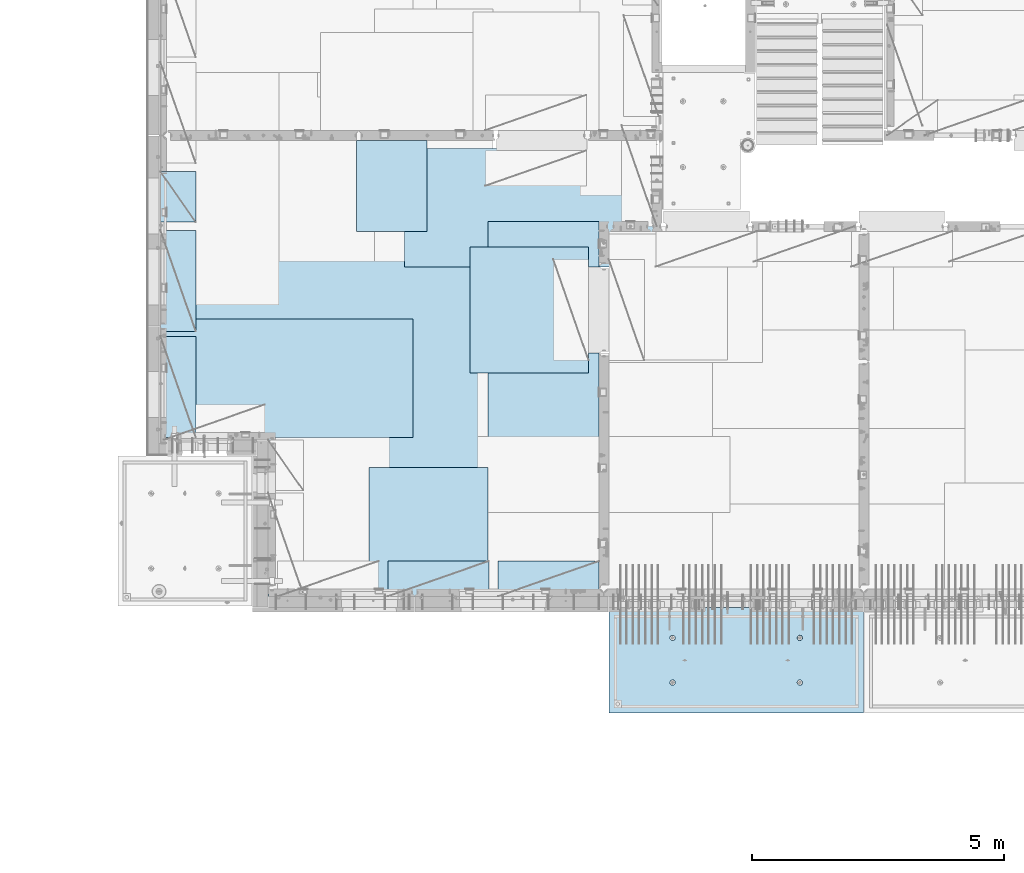
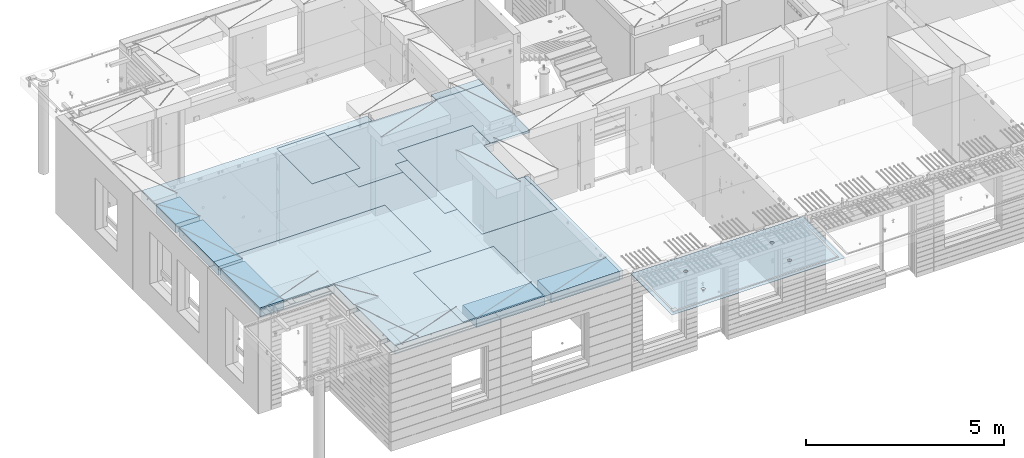
# One storey, part 193 of 334: 11 plates, 2 slabs, 11 elements without a shape of their own.
"""IFC2X3 building model written with IfcOpenShell, lengths in millimetres."""

from ifc_helpers import new_model, si_unit, frame, origin_with_axes, place, context, subcontext, project, spatial, faceted_brep, material, type_object, element, aggregate, save


model = new_model("IFC2X3")

# Units and contexts
model_context = context("Model", 3, precision=1e-05, world=origin_with_axes())
body_context = subcontext(model_context, "Body", "Model", "MODEL_VIEW")
ifc_project = project(units=[si_unit("LENGTHUNIT", "METRE", prefix="MILLI"), si_unit("AREAUNIT", "SQUARE_METRE"), si_unit("VOLUMEUNIT", "CUBIC_METRE"), si_unit("MASSUNIT", "GRAM", prefix="KILO"), si_unit("TIMEUNIT", "SECOND"), si_unit("PLANEANGLEUNIT", "RADIAN"), si_unit("SOLIDANGLEUNIT", "STERADIAN"), si_unit("THERMODYNAMICTEMPERATUREUNIT", "DEGREE_CELSIUS"), si_unit("LUMINOUSINTENSITYUNIT", "LUMEN")], contexts=[model_context])

# Site, building, storey
site_placement = place(None, origin_with_axes())
site = spatial("IfcSite", under=ifc_project, at=site_placement, CompositionType="ELEMENT")
building_placement = place(site_placement, origin_with_axes())
building = spatial("IfcBuilding", under=site, at=building_placement, CompositionType="ELEMENT")
storey_placement = place(building_placement, origin_with_axes())
storey = spatial("IfcBuildingStorey", under=building, at=storey_placement, Name="3", CompositionType="ELEMENT", Elevation=0.0)

# Assembly, slab
assembly_1_placement = place(storey_placement, origin_with_axes())
assembly_1 = element("IfcElementAssembly", 1, at=assembly_1_placement, inside=storey, AssemblyPlace="NOTDEFINED", PredefinedType="REINFORCEMENT_UNIT")
ifc_material_1 = material(Name="CONCRETE/C35/45")
slab_type_1 = type_object("IfcSlabType", PredefinedType="NOTDEFINED")
slab_1_placement = place(assembly_1_placement, frame((21799.9998568133, 7629.99655735226, 90720.0), z_axis=(-1.11800000013248e-06, -0.999999999999375, 0.0), x_axis=(-0.999999999999093, 1.34699999998405e-06, 0.0)))
slab_1 = element("IfcSlab", 2, at=slab_1_placement, type_object=slab_type_1, material=ifc_material_1, PredefinedType="FLOOR", context=body_context, shape_type="Brep", body=[
    faceted_brep([(3730.38290548735, -4.08996566387941, 616.12216176429), (3731.90567362447, 10.0, 615.627386703446), (3739.08833473806, 10.0, 629.724200466487), (3737.80580686752, -3.95055250760925, 630.656008831066), (3750.27560641379, 10.0, 640.911502705889), (3749.35118053074, -3.83997377335618, 642.183862123165), (3764.37240055375, 10.0, 648.094202331947), (3763.88889206625, -3.76900584615942, 649.582281527485), (3779.99882472937, 10.0, 650.569206660445), (3779.99882259584, -3.74455690493051, 652.131088126915), (3795.62525566664, 10.0, 648.094245023346), (3796.1087600739, -3.76900542440126, 649.582325494244), (3809.72206942968, 10.0, 640.911583909758), (3810.64649178305, -3.83997297089081, 642.183945778786), (3820.90937166908, 10.0, 629.724312234022), (3822.19189689232, -3.95055140258046, 630.656124028656), (3828.09207129514, 10.0, 615.627518094066), (3829.61483794004, -4.08996436404414, 616.122297269464), (3830.56707562364, 10.0, 600.001093918447), (3832.18578061358, -4.24460391153116, 600.001096129598), (3828.09211398654, 10.0, 584.374662981175), (3829.64831848373, -4.39934773846471, 583.869023838871), (3820.90945287295, 10.0, 570.277849218135), (3822.24608208202, -4.53903372617788, 569.306734043194), (3809.72218119721, 10.0, 559.090546978732), (3810.70070853473, -4.64994969953841, 557.743723511573), (3795.62538705726, 10.0, 551.907847352675), (3796.14233218844, -4.72119045964791, 550.316861227655), (3779.99896288164, 10.0, 549.432843024176), (3779.99896517058, -4.74574361447594, 547.757190340714), (3764.37253194437, 10.0, 551.907804661275), (3763.85559114489, -4.72119088313775, 550.316817078197), (3750.27571818133, 10.0, 559.090465774863), (3749.29719446955, -4.6499505048414, 557.743639560339), (3739.08841594193, 10.0, 570.277737450599), (3737.75178928409, -4.53903483404429, 569.306618549992), (3731.90571631587, 10.0, 584.374531590555), (3730.34951305942, -4.39934904004622, 583.868888150996), (3729.43071198737, 10.0, 600.000955766174), (3727.81200684201, -4.24460527917836, 600.000953555023), (0.0, 10.0, 0.0), (0.0, -10.0, 0.0), (0.000328360383718973, 10.0, 2085.00366210938), (5040.0, 10.0, -2.18278728425503e-09), (5040.0, -10.0, -2.18278728425503e-09), (5040.00048828125, 10.0, 2085.00366210938), (1210.18496592851, 4.0893025782425, 1468.8123736889), (1210.82376192895, 10.0, 1469.01993205604), (1208.29313952565, 10.0, 1484.99751183111), (1207.63911173254, 4.24455542066426, 1484.99751093771), (1217.61159442581, 3.94915724093153, 1454.20219661341), (1218.16787053537, 10.0, 1454.6063560253), (1229.19498209749, 3.837876675796, 1442.60117732261), (1229.60657282509, 10.0, 1443.16768498606), (1243.80127350603, 3.76640192835475, 1435.14992181469), (1244.02016891989, 10.0, 1435.82361575756), (1259.99775658, 3.74176842256566, 1432.58187432577), (1259.99775560856, 10.0, 1433.29303700502), (1276.19423262309, 3.76640235324157, 1435.14996610939), (1275.97533538363, 10.0, 1435.82365940832), (1290.8005036357, 3.83787748374743, 1442.60126155003), (1290.38891141437, 10.0, 1443.16776801473), (1302.38385956513, 3.94915835243592, 1454.20231248656), (1301.82758245361, 10.0, 1454.60647030446), (1309.81044810845, 4.08930388411682, 1468.81250982317), (1309.17165168211, 10.0, 1469.02006639926), (1312.35625807182, 4.244556792808, 1484.99765398133), (1311.70223043464, 10.0, 1484.99765308793), (1309.77685741928, 4.39970507899125, 1501.17189122433), (1309.17160803135, 10.0, 1500.975232863), (1302.32949611505, 4.53957668620569, 1515.75353188573), (1301.82749942493, 10.0, 1515.38880889374), (1290.74610851982, 4.65051890275208, 1527.31927827547), (1290.3887971352, 10.0, 1526.82747993297), (1276.16055006181, 4.72171992080985, 1534.74199744468), (1275.97520104041, 10.0, 1534.17154916147), (1259.99761353621, 4.74624887190294, 1537.29914508766), (1259.99761435174, 10.0, 1536.70212791401), (1243.83468398195, 4.72171949766926, 1534.74195333328), (1244.02003457667, 10.0, 1534.17150551072), (1229.24914576394, 4.65051809765282, 1527.31919434463), (1229.60645854592, 10.0, 1526.8273969043), (1217.66578971822, 4.53957557752437, 1515.75341630916), (1218.16778750669, 10.0, 1515.38869461457), (1210.21846821205, 4.39970377489226, 1501.17175527336), (1210.82371827819, 10.0, 1500.97509851978), (1210.34950957413, -4.39938207223895, 583.86544460908), (1211.90571640051, 10.0, 584.371089208588), (1209.43071207202, 10.0, 599.997513384207), (1207.81200317426, -4.24463830025343, 599.997511173051), (1217.75178633104, -4.53906787629239, 569.303173961003), (1219.08841602657, 10.0, 570.274295068632), (1229.29719234665, -4.64998355506395, 557.740194139937), (1230.27571826597, 10.0, 559.087023392896), (1243.85559006878, -4.72122393849713, 550.313371123784), (1244.37253202901, 10.0, 551.904362279308), (1259.99896525523, -4.74577667158155, 547.753744202259), (1259.99896296629, 10.0, 549.429400642209), (1276.14233343384, -4.72122351497819, 550.313415273247), (1275.6253871419, 10.0, 551.904404970708), (1290.70071082692, -4.64998274977552, 557.740278091178), (1289.72218128186, 10.0, 559.087104596765), (1302.24608520437, -4.53906676842598, 569.303289454215), (1300.9094529576, 10.0, 570.274406836168), (1309.64832213832, -4.39938077065744, 583.865580296964), (1308.09211407118, 10.0, 584.371220599208), (1312.18578445062, -4.24463693260623, 599.997653747636), (1310.56707570828, 10.0, 599.99765153648), (1309.61484159223, -4.08999737400154, 616.118856046664), (1308.09207137979, 10.0, 615.624075712099), (1302.19190001076, -3.95058440251159, 630.652683850883), (1300.90937175373, 10.0, 629.720869852055), (1290.64649407134, -3.8400059628766, 642.180506429899), (1289.72206951433, 10.0, 640.908141527791), (1276.10876131689, -3.76903841129388, 649.578886677323), (1275.62525575129, 10.0, 648.090802641378), (1259.99882268048, -3.74458989004779, 652.127649493255), (1259.99882481401, 10.0, 650.565764278478), (1243.88889099253, -3.76903883303748, 649.578842710559), (1244.37240063839, 10.0, 648.090759949978), (1229.35117841172, -3.84000676534197, 642.180422774271), (1230.27560649844, 10.0, 640.908060323922), (1217.80580391836, -3.95058550754038, 630.652568653284), (1219.0883348227, 10.0, 629.72075808452), (1210.38290200446, -4.08999867383682, 616.11872054148), (1211.90567370912, 10.0, 615.623944321479), (3795.97520095576, 10.0, 1534.17499154344), (3796.16054881881, 4.72175290768791, 1534.7454362616), (3779.99761345157, 4.74628185702022, 1537.30258372132), (3779.99761426709, 10.0, 1536.70557029598), (3810.38879705055, 10.0, 1526.83092231494), (3810.74610623151, 4.65055189473787, 1527.32271762435), (3821.82749934028, 10.0, 1515.39225127571), (3822.3294929966, 4.53960968612228, 1515.75697206351), (3829.1716079467, 10.0, 1500.97867524496), (3829.7768537671, 4.39973808894865, 1501.17533244712), (3831.70223035, 10.0, 1485.00109546989), (3832.35625423479, 4.24458981388307, 1485.00109636329), (3829.17165159746, 10.0, 1469.02350878122), (3829.81044445387, 4.08933691630955, 1468.81595336508), (3821.82758236896, 10.0, 1454.60991268643), (3822.38385644279, 3.94919139468402, 1454.20575707554), (3810.38891132972, 10.0, 1443.1712103967), (3810.8005013435, 3.83791053396999, 1442.60470697043), (3795.97533529899, 10.0, 1435.82710179029), (3796.19423137769, 3.76643540860096, 1435.1534120638), (3779.99775552391, 10.0, 1433.29647938699), (3779.99775649536, 3.74180147968582, 1432.58532046422), (3764.02016883524, 10.0, 1435.82705813953), (3763.80127458214, 3.76643498368503, 1435.1533677691), (3749.60657274045, 10.0, 1443.17112736803), (3749.19498422039, 3.837909726004, 1442.60462274301), (3738.16787045072, 10.0, 1454.60979840726), (3737.61159737886, 3.94919028317963, 1454.2056412024), (3730.82376184431, 10.0, 1469.023374438), (3730.18496941381, 4.08933561044978, 1468.81581723082), (3737.66579266739, 4.53960857747006, 1515.75685648694), (3749.24914788297, 4.65055108962406, 1527.32263369353), (3763.83468505566, 4.72175248454732, 1534.7453921502), (3727.63911540029, 4.24458844172477, 1485.00095331968), (3730.21847169495, 4.39973678484967, 1501.17519649617), (3764.02003449202, 10.0, 1534.17494789268), (3749.60645846128, 10.0, 1526.83083928627), (3738.16778742204, 10.0, 1515.39213699654), (3730.82371819355, 10.0, 1500.97854090175), (3728.293139441, 10.0, 1485.00095421308)], [[[0, 1, 2, 3]], [[3, 2, 4, 5]], [[5, 4, 6, 7]], [[7, 6, 8, 9]], [[10, 11, 9, 8]], [[12, 13, 11, 10]], [[14, 15, 13, 12]], [[16, 17, 15, 14]], [[18, 19, 17, 16]], [[20, 21, 19, 18]], [[22, 23, 21, 20]], [[24, 25, 23, 22]], [[26, 27, 25, 24]], [[27, 26, 28, 29]], [[29, 28, 30, 31]], [[31, 30, 32, 33]], [[33, 32, 34, 35]], [[35, 34, 36, 37]], [[37, 36, 38, 39]], [[39, 38, 1, 0]], [[40, 41, 42]], [[40, 43, 44, 41]], [[43, 45, 44]], [[46, 47, 48, 49]], [[50, 51, 47, 46]], [[52, 53, 51, 50]], [[54, 55, 53, 52]], [[56, 57, 55, 54]], [[58, 59, 57, 56]], [[60, 61, 59, 58]], [[61, 60, 62, 63]], [[63, 62, 64, 65]], [[65, 64, 66, 67]], [[67, 66, 68, 69]], [[69, 68, 70, 71]], [[71, 70, 72, 73]], [[73, 72, 74, 75]], [[75, 74, 76, 77]], [[77, 76, 78, 79]], [[80, 81, 79, 78]], [[82, 83, 81, 80]], [[84, 85, 83, 82]], [[49, 48, 85, 84]], [[86, 87, 88, 89]], [[90, 91, 87, 86]], [[92, 93, 91, 90]], [[94, 95, 93, 92]], [[96, 97, 95, 94]], [[98, 99, 97, 96]], [[99, 98, 100, 101]], [[101, 100, 102, 103]], [[103, 102, 104, 105]], [[105, 104, 106, 107]], [[107, 106, 108, 109]], [[109, 108, 110, 111]], [[111, 110, 112, 113]], [[113, 112, 114, 115]], [[115, 114, 116, 117]], [[118, 119, 117, 116]], [[120, 121, 119, 118]], [[122, 123, 121, 120]], [[124, 125, 123, 122]], [[89, 88, 125, 124]], [[126, 127, 128, 129]], [[130, 131, 127, 126]], [[132, 133, 131, 130]], [[134, 135, 133, 132]], [[136, 137, 135, 134]], [[138, 139, 137, 136]], [[140, 141, 139, 138]], [[142, 143, 141, 140]], [[143, 142, 144, 145]], [[145, 144, 146, 147]], [[147, 146, 148, 149]], [[149, 148, 150, 151]], [[151, 150, 152, 153]], [[153, 152, 154, 155]], [[41, 44, 45, 42], [3, 5, 7, 9, 11, 13, 15, 17, 19, 21, 23, 25, 27, 29, 31, 33, 35, 37, 39, 0], [156, 157, 158, 128, 127, 131, 133, 135, 137, 139, 141, 143, 145, 147, 149, 151, 153, 155, 159, 160], [122, 120, 118, 116, 114, 112, 110, 108, 106, 104, 102, 100, 98, 96, 94, 92, 90, 86, 89, 124], [82, 80, 78, 76, 74, 72, 70, 68, 66, 64, 62, 60, 58, 56, 54, 52, 50, 46, 49, 84]], [[129, 128, 158, 161]], [[157, 162, 161, 158]], [[156, 163, 162, 157]], [[160, 164, 163, 156]], [[159, 165, 164, 160]], [[155, 154, 165, 159]], [[43, 40, 42, 45], [34, 32, 30, 28, 26, 24, 22, 20, 18, 16, 14, 12, 10, 8, 6, 4, 2, 1, 38, 36], [152, 150, 148, 146, 144, 142, 140, 138, 136, 134, 132, 130, 126, 129, 161, 162, 163, 164, 165, 154], [91, 93, 95, 97, 99, 101, 103, 105, 107, 109, 111, 113, 115, 117, 119, 121, 123, 125, 88, 87], [51, 53, 55, 57, 59, 61, 63, 65, 67, 69, 71, 73, 75, 77, 79, 81, 83, 85, 48, 47]]]),
])
aggregate(assembly_1, [slab_1])

# Assembly, plate
assembly_2_placement = place(storey_placement, origin_with_axes())
assembly_2 = element("IfcElementAssembly", 3, at=assembly_2_placement, inside=storey, Name="Steel Assembly", AssemblyPlace="NOTDEFINED", PredefinedType="NOTDEFINED")
ifc_material_2 = material()
plate_type_1 = type_object("IfcPlateType", PredefinedType="NOTDEFINED")
plate_1_placement = place(assembly_2_placement, frame((14009.7695320312, 12275.0000289158, 90695.1), z_axis=(0.0, 1.0, 0.0), x_axis=(1.0, 0.0, 0.0)))
plate_1 = element("IfcPlate", 4, at=plate_1_placement, type_object=plate_type_1, material=ifc_material_2, Name="1/2", context=body_context, shape_type="Brep", body=[
    faceted_brep([(0.0, -35.0, 0.0), (0.0, -35.0, 2500.0), (0.0, 35.0, 2500.0), (0.0, 35.0, 0.0), (2349.99951171875, -35.0, 2500.0), (2349.99951171875, 35.0, 2500.0), (2350.0, -35.0, 0.0), (2350.0, 35.0, 0.0)], [[[0, 1, 2, 3]], [[1, 4, 5, 2]], [[4, 6, 7, 5]], [[6, 0, 3, 7]], [[5, 7, 3, 2]], [[6, 4, 1, 0]]]),
])
aggregate(assembly_2, [plate_1])

assembly_3_placement = place(storey_placement, origin_with_axes())
assembly_3 = element("IfcElementAssembly", 5, at=assembly_3_placement, inside=storey, Name="Steel Assembly", AssemblyPlace="NOTDEFINED", PredefinedType="NOTDEFINED")
plate_2_placement = place(assembly_3_placement, frame((14360.0, 10400.0, 90695.1), z_axis=(0.0, -1.0, 0.0), x_axis=(-1.0, 3.00000001838171e-08, 0.0)))
plate_2 = element("IfcPlate", 6, at=plate_2_placement, type_object=plate_type_1, material=ifc_material_2, Name="1/2", context=body_context, shape_type="Brep", body=[
    faceted_brep([(0.0, -35.0, 0.0), (0.0, -35.0, 2500.0), (0.0, 35.0, 2500.0), (0.0, 35.0, 0.0), (2349.99951171875, -35.0, 2500.0), (2349.99951171875, 35.0, 2500.0), (2350.0, -35.0, 0.0), (2350.0, 35.0, 0.0)], [[[0, 1, 2, 3]], [[1, 4, 5, 2]], [[4, 6, 7, 5]], [[6, 0, 3, 7]], [[5, 7, 3, 2]], [[6, 4, 1, 0]]]),
])
aggregate(assembly_3, [plate_2])

assembly_4_placement = place(storey_placement, origin_with_axes())
assembly_4 = element("IfcElementAssembly", 7, at=assembly_4_placement, inside=storey, Name="Steel Assembly", AssemblyPlace="NOTDEFINED", PredefinedType="NOTDEFINED")
plate_3_placement = place(assembly_4_placement, frame((12710.0, 16725.0, 90695.1), z_axis=(1.0, 0.0, 0.0), x_axis=(0.0, -1.0, 0.0)))
plate_3 = element("IfcPlate", 8, at=plate_3_placement, type_object=plate_type_1, material=ifc_material_2, context=body_context, shape_type="Brep", body=[
    faceted_brep([(0.0, -35.0, 0.0), (0.0, -35.0, 5000.0), (0.0, 35.0, 5000.0), (0.0, 35.0, 0.0), (2349.99951171875, -35.0, 5000.0), (2349.99951171875, 35.0, 5000.0), (2350.0, -35.0, 0.0), (2350.0, 35.0, 0.0)], [[[0, 1, 2, 3]], [[1, 4, 5, 2]], [[4, 6, 7, 5]], [[6, 0, 3, 7]], [[5, 7, 3, 2]], [[6, 4, 1, 0]]]),
])
aggregate(assembly_4, [plate_3])

assembly_5_placement = place(storey_placement, origin_with_axes())
assembly_5 = element("IfcElementAssembly", 9, at=assembly_5_placement, inside=storey, Name="Steel Assembly", AssemblyPlace="NOTDEFINED", PredefinedType="NOTDEFINED")
plate_4_placement = place(assembly_5_placement, frame((12880.0, 11000.0, 90695.1), z_axis=(-1.0, 3.00000001838171e-08, 0.0), x_axis=(0.0, 1.0, 0.0)))
plate_4 = element("IfcPlate", 10, at=plate_4_placement, type_object=plate_type_1, material=ifc_material_2, context=body_context, shape_type="Brep", body=[
    faceted_brep([(0.0, -35.0, 0.0), (0.0, -35.0, 5000.0), (0.0, 35.0, 5000.0), (0.0, 35.0, 0.0), (2349.99951171875, -35.0, 5000.0), (2349.99951171875, 35.0, 5000.0), (2350.0, -35.0, 0.0), (2350.0, 35.0, 0.0)], [[[0, 1, 2, 3]], [[1, 4, 5, 2]], [[4, 6, 7, 5]], [[6, 0, 3, 7]], [[5, 7, 3, 2]], [[6, 4, 1, 0]]]),
])
aggregate(assembly_5, [plate_4])

assembly_6_placement = place(storey_placement, origin_with_axes())
assembly_6 = element("IfcElementAssembly", 11, at=assembly_6_placement, inside=storey, Name="Steel Assembly", AssemblyPlace="NOTDEFINED", PredefinedType="NOTDEFINED")
plate_type_2 = type_object("IfcPlateType", PredefinedType="NOTDEFINED")
plate_5_placement = place(assembly_6_placement, frame((7879.99987792969, 13000.0, 90595.3), z_axis=(1.0, 0.0, 0.0), x_axis=(0.0, -1.0, 0.0)))
plate_5 = element("IfcPlate", 12, at=plate_5_placement, type_object=plate_type_2, material=ifc_material_2, Name="RE1", context=body_context, shape_type="Brep", body=[
    faceted_brep([(1.81898940354586e-12, -135.0, 1.81898940354586e-12), (0.0, -135.0, 699.999999999996), (0.0, 135.0, 699.999999999996), (1.81898940354586e-12, 135.0, 1.81898940354586e-12), (1999.99951171875, -135.0, 699.999999999993), (1999.99951171875, 135.0, 699.999999999993), (2000.0, -135.0, -3.63797880709171e-12), (2000.0, 135.0, -3.63797880709171e-12)], [[[0, 1, 2, 3]], [[1, 4, 5, 2]], [[4, 6, 7, 5]], [[6, 0, 3, 7]], [[5, 7, 3, 2]], [[6, 4, 1, 0]]]),
])
aggregate(assembly_6, [plate_5])

assembly_7_placement = place(storey_placement, origin_with_axes())
assembly_7 = element("IfcElementAssembly", 13, at=assembly_7_placement, inside=storey, Name="Steel Assembly", AssemblyPlace="NOTDEFINED", PredefinedType="NOTDEFINED")
plate_6_placement = place(assembly_7_placement, frame((7879.99999992931, 16265.0, 90595.3), z_axis=(1.0, 0.0, 0.0), x_axis=(0.0, -1.0, 0.0)))
plate_6 = element("IfcPlate", 14, at=plate_6_placement, type_object=plate_type_2, material=ifc_material_2, Name="RE1_1/2", context=body_context, shape_type="Brep", body=[
    faceted_brep([(1.81898940354586e-12, -135.0, 1.81898940354586e-12), (0.0, -135.0, 699.999999999996), (0.0, 135.0, 699.999999999996), (1.81898940354586e-12, 135.0, 1.81898940354586e-12), (999.99951171875, -135.0, 700.0), (999.99951171875, 135.0, 700.0), (1000.0, -135.0, 0.0), (1000.0, 135.0, 0.0)], [[[0, 1, 2, 3]], [[1, 4, 5, 2]], [[4, 6, 7, 5]], [[6, 0, 3, 7]], [[5, 7, 3, 2]], [[6, 4, 1, 0]]]),
])
aggregate(assembly_7, [plate_6])

assembly_8_placement = place(storey_placement, origin_with_axes())
assembly_8 = element("IfcElementAssembly", 15, at=assembly_8_placement, inside=storey, Name="Steel Assembly", AssemblyPlace="NOTDEFINED", PredefinedType="NOTDEFINED")
plate_7_placement = place(assembly_8_placement, frame((14565.0008542386, 7850.00010363356, 90595.3), z_axis=(0.0, 1.0, 0.0), x_axis=(1.0, 0.0, 0.0)))
plate_7 = element("IfcPlate", 16, at=plate_7_placement, type_object=plate_type_2, material=ifc_material_2, Name="RE1", context=body_context, shape_type="Brep", body=[
    faceted_brep([(1.81898940354586e-12, -135.0, 1.81898940354586e-12), (0.0, -135.0, 699.999999999996), (0.0, 135.0, 699.999999999996), (1.81898940354586e-12, 135.0, 1.81898940354586e-12), (1999.99951171875, -135.0, 699.999999999993), (1999.99951171875, 135.0, 699.999999999993), (2000.0, -135.0, -3.63797880709171e-12), (2000.0, 135.0, -3.63797880709171e-12)], [[[0, 1, 2, 3]], [[1, 4, 5, 2]], [[4, 6, 7, 5]], [[6, 0, 3, 7]], [[5, 7, 3, 2]], [[6, 4, 1, 0]]]),
])
aggregate(assembly_8, [plate_7])

assembly_9_placement = place(storey_placement, origin_with_axes())
assembly_9 = element("IfcElementAssembly", 17, at=assembly_9_placement, inside=storey, Name="Steel Assembly", AssemblyPlace="NOTDEFINED", PredefinedType="NOTDEFINED")
plate_8_placement = place(assembly_9_placement, frame((12382.5008542386, 7850.00010363356, 90595.3), z_axis=(0.0, 1.0, 0.0), x_axis=(1.0, 0.0, 0.0)))
plate_8 = element("IfcPlate", 18, at=plate_8_placement, type_object=plate_type_2, material=ifc_material_2, Name="RE1", context=body_context, shape_type="Brep", body=[
    faceted_brep([(1.81898940354586e-12, -135.0, 1.81898940354586e-12), (0.0, -135.0, 699.999999999996), (0.0, 135.0, 699.999999999996), (1.81898940354586e-12, 135.0, 1.81898940354586e-12), (1999.99951171875, -135.0, 699.999999999993), (1999.99951171875, 135.0, 699.999999999993), (2000.0, -135.0, -3.63797880709171e-12), (2000.0, 135.0, -3.63797880709171e-12)], [[[0, 1, 2, 3]], [[1, 4, 5, 2]], [[4, 6, 7, 5]], [[6, 0, 3, 7]], [[5, 7, 3, 2]], [[6, 4, 1, 0]]]),
])
aggregate(assembly_9, [plate_8])

assembly_10_placement = place(storey_placement, origin_with_axes())
assembly_10 = element("IfcElementAssembly", 19, at=assembly_10_placement, inside=storey, Name="Steel Assembly", AssemblyPlace="NOTDEFINED", PredefinedType="NOTDEFINED")
plate_9_placement = place(assembly_10_placement, frame((7879.99987792969, 15100.0, 90595.3), z_axis=(1.0, 0.0, 0.0), x_axis=(0.0, -1.0, 0.0)))
plate_9 = element("IfcPlate", 20, at=plate_9_placement, type_object=plate_type_2, material=ifc_material_2, Name="RE1", context=body_context, shape_type="Brep", body=[
    faceted_brep([(1.81898940354586e-12, -135.0, 1.81898940354586e-12), (0.0, -135.0, 699.999999999996), (0.0, 135.0, 699.999999999996), (1.81898940354586e-12, 135.0, 1.81898940354586e-12), (1999.99951171875, -135.0, 699.999999999993), (1999.99951171875, 135.0, 699.999999999993), (2000.0, -135.0, -3.63797880709171e-12), (2000.0, 135.0, -3.63797880709171e-12)], [[[0, 1, 2, 3]], [[1, 4, 5, 2]], [[4, 6, 7, 5]], [[6, 0, 3, 7]], [[5, 7, 3, 2]], [[6, 4, 1, 0]]]),
])
aggregate(assembly_10, [plate_9])

# Assembly, plates, slab
assembly_11_placement = place(storey_placement, origin_with_axes())
assembly_11 = element("IfcElementAssembly", 21, at=assembly_11_placement, inside=storey, AssemblyPlace="NOTDEFINED", PredefinedType="REINFORCEMENT_UNIT")
plate_type_3 = type_object("IfcPlateType", PredefinedType="NOTDEFINED")
plate_10_placement = place(assembly_11_placement, frame((13159.9998642727, 15079.9997757405, 90725.45), z_axis=(-1.0, 3.00000001838171e-08, 0.0), x_axis=(0.0, 1.0, 0.0)))
plate_10 = element("IfcPlate", 22, at=plate_10_placement, type_object=plate_type_3, material=ifc_material_2, context=body_context, shape_type="Brep", body=[
    faceted_brep([(0.0, -5.0, 0.0), (0.0, -5.0, 1399.99963378906), (0.0, 5.0, 1399.99963378906), (0.0, 5.0, 0.0), (1800.00024414063, -5.0, 1399.99963378906), (1800.00024414063, 5.0, 1399.99963378906), (1800.00024414063, -5.0, 0.0), (1800.00024414063, 5.0, 0.0)], [[[0, 1, 2, 3]], [[1, 4, 5, 2]], [[4, 6, 7, 5]], [[6, 0, 3, 7]], [[5, 7, 3, 2]], [[6, 4, 1, 0]]]),
])
plate_type_4 = type_object("IfcPlateType", PredefinedType="NOTDEFINED")
plate_11_placement = place(assembly_11_placement, frame((16559.9994828029, 15279.9995850056, 90725.45), z_axis=(0.0, -1.0, 0.0), x_axis=(-1.0, 3.00000001838171e-08, 0.0)))
plate_11 = element("IfcPlate", 23, at=plate_11_placement, type_object=plate_type_4, material=ifc_material_2, context=body_context, shape_type="Brep", body=[
    faceted_brep([(0.0, -5.0, 2604.99950854713), (0.0, 5.0, 2604.99950854713), (200.234115600586, 5.0, 2604.99950854713), (200.234115600586, -5.0, 2604.99950854713), (200.234115600586, 5.0, 904.999508547127), (200.234115600586, -5.0, 904.999508547127), (0.0, -5.0, 904.999508547127), (0.0, 5.0, 904.999508547127), (0.0, -5.0, 4271.99951171875), (2191.99951171875, -5.0, 4271.99951171875), (2191.99951171875, 5.0, 4271.99951171875), (0.0, 5.0, 4271.99951171875), (2191.99951171875, -5.0, 0.0), (2191.99951171875, 5.0, 0.0), (0.0, -5.0, 0.0), (0.0, 5.0, 0.0)], [[[0, 1, 2, 3]], [[3, 2, 4, 5]], [[6, 5, 4, 7]], [[8, 9, 10, 11]], [[9, 12, 13, 10]], [[12, 14, 15, 13]], [[15, 14, 6, 7]], [[2, 1, 11, 10, 13, 15, 7, 4]], [[8, 11, 1, 0]], [[14, 12, 9, 8, 0, 3, 5, 6]]]),
])
ifc_material_3 = material(Name="CONCRETE/C30/37")
slab_type_2 = type_object("IfcSlabType", PredefinedType="NOTDEFINED")
slab_2_placement = place(assembly_11_placement, frame((10010.0, 7850.0, 90595.0), z_axis=(0.0, 1.0, 0.0), x_axis=(1.0, 0.0, 0.0)))
slab_2 = element("IfcSlab", 24, at=slab_2_placement, type_object=slab_type_2, material=ifc_material_3, PredefinedType="FLOOR", context=body_context, shape_type="Brep", body=[
    faceted_brep([(6153.68914550781, -135.0, 8830.0), (4520.0, -135.0, 8830.0), (4453.69, -135.0, 8830.0), (4453.68914550781, -135.0, 9130.0), (-2130.0, -135.0, 9130.0), (-2130.0, -135.0, 3100.0), (0.0, -135.0, 3100.0), (1.81898940354586e-12, -135.0, 1.81898940354586e-12), (6650.0, -135.0, 0.0), (6650.0, -135.0, 4825.00007645847), (6349.76536720235, -135.0, 4825.00007645847), (6349.76536720235, -135.0, 6525.00007645847), (6649.76537407247, -135.0, 6525.00007645847), (6650.0, -135.0, 7330.0), (7700.0, -135.0, 7330.0), (7700.0, -135.0, 9130.0), (6319.99914550781, -135.0, 9130.0), (6319.99914550781, -135.0, 8830.0), (-2130.0, 135.0, 9130.0), (4453.68914550781, 135.0, 9130.0), (-2130.0, 135.0, 3100.0), (0.0, 135.0, 3100.0), (1.81898940354586e-12, 135.0, 1.81898940354586e-12), (6650.0, 135.0, 0.0), (6650.0, 135.0, 4825.00007645847), (6349.76536720235, 135.0, 4825.00007645847), (6349.76536720235, 135.0, 6525.00007645847), (6650.0, 135.0, 6525.00007645847), (6650.0, 135.0, 7330.0), (7700.0, 135.0, 7330.0), (7700.0, 135.0, 9130.0), (6319.99914550781, 135.0, 9130.0), (6319.99914550781, 135.0, 8830.0), (6153.68914550781, 135.0, 8830.0), (4453.69, 135.0, 8830.0), (4520.0, 135.0, 8830.0)], [[[0, 1, 2, 3, 4, 5, 6, 7, 8, 9, 10, 11, 12, 13, 14, 15, 16, 17]], [[18, 4, 3, 19]], [[5, 4, 18, 20]], [[6, 5, 20, 21]], [[7, 6, 21, 22]], [[8, 7, 22, 23]], [[8, 23, 24, 9]], [[9, 24, 25, 10]], [[10, 25, 26, 11]], [[12, 11, 26, 27]], [[28, 13, 12, 27]], [[14, 13, 28, 29]], [[15, 14, 29, 30]], [[15, 30, 31, 16]], [[16, 31, 32, 17]], [[33, 32, 31, 30, 29, 28, 27, 26, 25, 24, 23, 22, 21, 20, 18, 19, 34, 35]], [[3, 2, 34, 19]], [[1, 0, 33, 35, 34, 2]], [[17, 32, 33, 0]]]),
])
aggregate(assembly_11, [plate_10, plate_11, slab_2])

save(model, "model.ifc")
